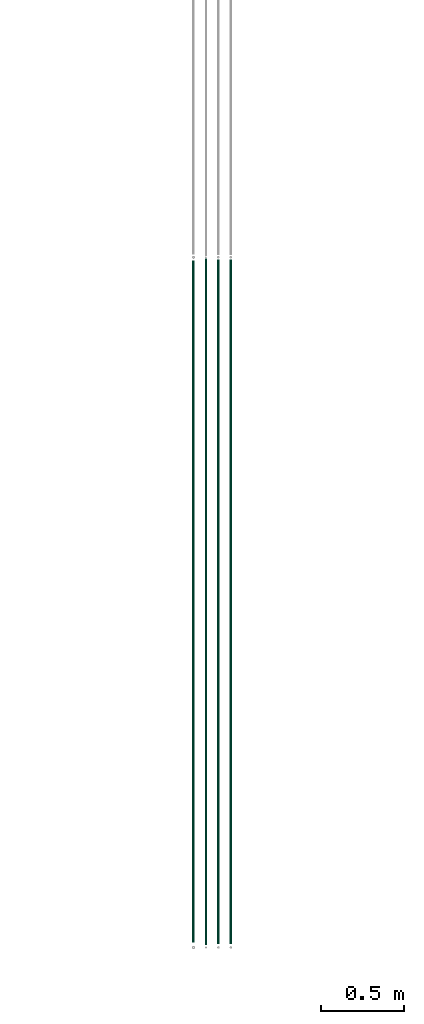
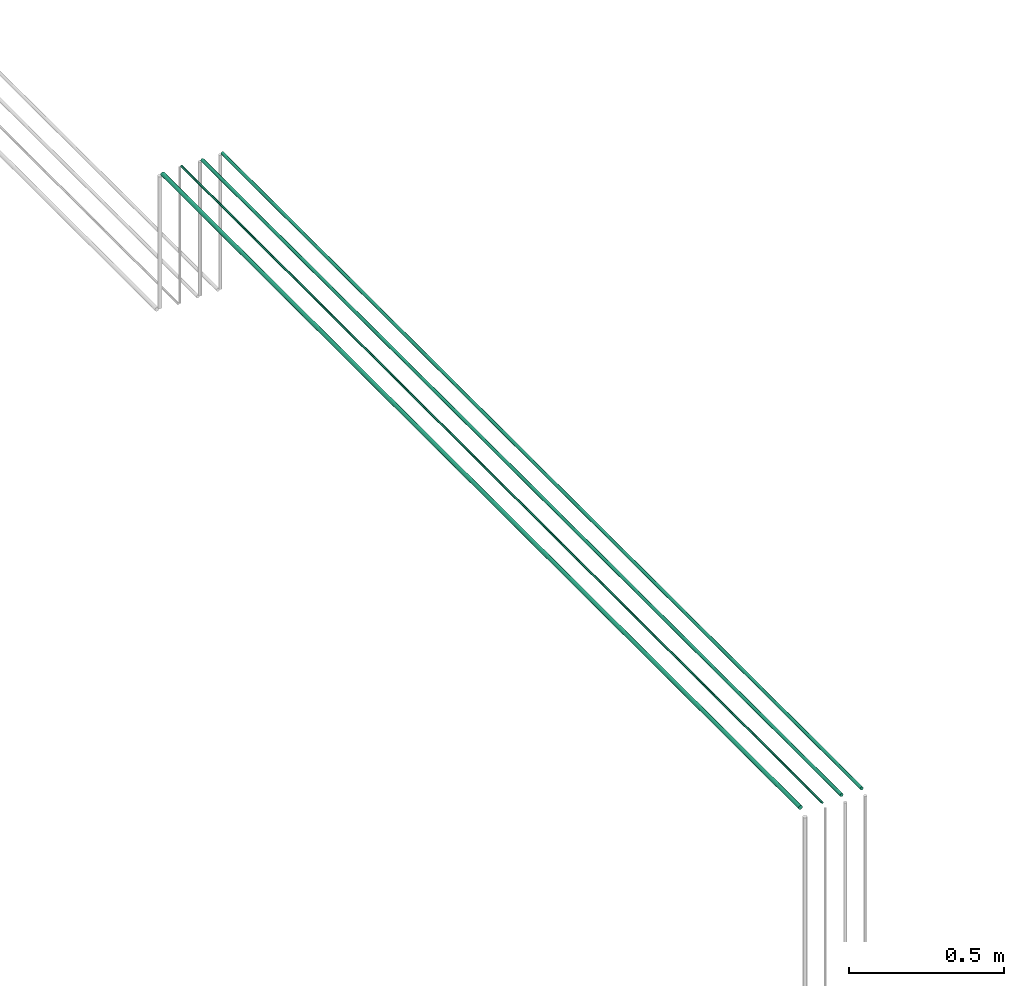
# One storey, part 9 of 65: 4 flow segments.
"""IFC2X3 building model written with IfcOpenShell, lengths in millimetres."""

from ifc_helpers import new_model, entity, si_unit, converted_unit, derived_unit, direction, frame, frame_2d, origin, origin_2d_with_axis, place, context, subcontext, project, spatial, circle, extrude, type_object, element, save


model = new_model("IFC2X3")

# Units and contexts
model_context = context("Model", 3, precision=0.01, world=origin(), true_north=direction((6.12303176911189e-17, 1.0)))
body_context = subcontext(model_context, "Body", "Model", "MODEL_VIEW")
ifc_project = project(units=[si_unit("LENGTHUNIT", "METRE", prefix="MILLI"), si_unit("AREAUNIT", "SQUARE_METRE"), si_unit("VOLUMEUNIT", "CUBIC_METRE"), converted_unit("PLANEANGLEUNIT", "DEGREE", entity("IfcRatioMeasure", 0.0174532925199433), si_unit("PLANEANGLEUNIT", "RADIAN"), dimensions=[0, 0, 0, 0, 0, 0, 0]), si_unit("MASSUNIT", "GRAM", prefix="KILO"), derived_unit("MASSDENSITYUNIT", [(si_unit("MASSUNIT", "GRAM", prefix="KILO"), 1), (si_unit("LENGTHUNIT", "METRE"), -3)]), derived_unit("MOMENTOFINERTIAUNIT", [(si_unit("LENGTHUNIT", "METRE"), 4)]), si_unit("TIMEUNIT", "SECOND"), si_unit("FREQUENCYUNIT", "HERTZ"), si_unit("THERMODYNAMICTEMPERATUREUNIT", "DEGREE_CELSIUS"), derived_unit("THERMALTRANSMITTANCEUNIT", [(si_unit("MASSUNIT", "GRAM", prefix="KILO"), 1), (si_unit("THERMODYNAMICTEMPERATUREUNIT", "KELVIN"), -1), (si_unit("TIMEUNIT", "SECOND"), -3)]), derived_unit("VOLUMETRICFLOWRATEUNIT", [(si_unit("LENGTHUNIT", "METRE"), 3), (si_unit("TIMEUNIT", "SECOND"), -1)]), derived_unit("MASSFLOWRATEUNIT", [(si_unit("MASSUNIT", "GRAM", prefix="KILO"), 1), (si_unit("TIMEUNIT", "SECOND"), -1)]), derived_unit("ROTATIONALFREQUENCYUNIT", [(si_unit("TIMEUNIT", "SECOND"), -1)]), si_unit("ELECTRICCURRENTUNIT", "AMPERE"), si_unit("ELECTRICVOLTAGEUNIT", "VOLT"), si_unit("POWERUNIT", "WATT"), si_unit("FORCEUNIT", "NEWTON", prefix="KILO"), si_unit("ILLUMINANCEUNIT", "LUX"), si_unit("LUMINOUSFLUXUNIT", "LUMEN"), si_unit("LUMINOUSINTENSITYUNIT", "CANDELA"), derived_unit("USERDEFINED", [(si_unit("MASSUNIT", "GRAM", prefix="KILO"), -1), (si_unit("LENGTHUNIT", "METRE"), -2), (si_unit("TIMEUNIT", "SECOND"), 3), (si_unit("LUMINOUSFLUXUNIT", "LUMEN"), 1)]), derived_unit("LINEARVELOCITYUNIT", [(si_unit("LENGTHUNIT", "METRE"), 1), (si_unit("TIMEUNIT", "SECOND"), -1)]), si_unit("PRESSUREUNIT", "PASCAL"), derived_unit("USERDEFINED", [(si_unit("LENGTHUNIT", "METRE"), -2), (si_unit("MASSUNIT", "GRAM", prefix="KILO"), 1), (si_unit("TIMEUNIT", "SECOND"), -2)]), derived_unit("LINEARFORCEUNIT", [(si_unit("MASSUNIT", "GRAM", prefix="KILO"), 1), (si_unit("LENGTHUNIT", "METRE"), 1), (si_unit("TIMEUNIT", "SECOND"), -2), (si_unit("LENGTHUNIT", "METRE"), -1)]), derived_unit("PLANARFORCEUNIT", [(si_unit("MASSUNIT", "GRAM", prefix="KILO"), 1), (si_unit("LENGTHUNIT", "METRE"), 1), (si_unit("TIMEUNIT", "SECOND"), -2), (si_unit("LENGTHUNIT", "METRE"), -2)])], contexts=[model_context])

# Site, building, storey
site_placement = place(None, frame((0.0, -0.00077364408347762, 0.0)))
site = spatial("IfcSite", under=ifc_project, at=site_placement, CompositionType="ELEMENT")
building_placement = place(site_placement, origin())
building = spatial("IfcBuilding", under=site, at=building_placement, CompositionType="ELEMENT")
storey_placement = place(building_placement, frame((0.0, 0.0, 19800.0)))
storey = spatial("IfcBuildingStorey", under=building, at=storey_placement, CompositionType="ELEMENT", Elevation=19800.0)

# Flow segments
pipe_segment_type = type_object("IfcPipeSegmentType", PredefinedType="NOTDEFINED")
flow_segment_1_placement = place(storey_placement, frame((50935.3052438068, 557.0, 3174.40472776419)))
element("IfcFlowSegment", 1, at=flow_segment_1_placement, inside=storey, type_object=pipe_segment_type, context=body_context, shape_type="SweptSolid", body=[
    extrude(circle(Radius=4.0, at=frame_2d((-8.66293703438714e-12, 0.0), x_axis=(1.0, 0.0))), frame((5.59527223591499, 0.0, 5.59527223591499), z_axis=(0.0, 1.0, 0.0), x_axis=(-1.0, 0.0, 0.0)), (0.0, 0.0, 1.0), 4133.00000000001),
])
for number, where in (
    (2, (51008.3052438068, 563.0, 3172.40472776425)),
    (3, (51083.3052438068, 563.0, 3172.40472776415)),
):
    element("IfcFlowSegment", number, at=place(storey_placement, frame(where)), inside=storey, type_object=pipe_segment_type, context=body_context, shape_type="SweptSolid", body=[
        extrude(circle(Radius=6.0, at=frame_2d((-8.66293703438714e-12, 0.0), x_axis=(1.0, 0.0))), frame((7.59527223591454, 0.0, 7.59527223591454), z_axis=(0.0, 1.0, 0.0), x_axis=(-1.0, 0.0, 0.0)), (0.0, 0.0, 1.0), 4123.00000000001),
    ])
flow_segment_2_placement = place(storey_placement, frame((50856.8052438068, 569.0, 3170.90472776367)))
element("IfcFlowSegment", 4, at=flow_segment_2_placement, inside=storey, type_object=pipe_segment_type, context=body_context, shape_type="SweptSolid", body=[
    extrude(circle(Radius=7.5, at=origin_2d_with_axis()), frame((9.09527223591419, 0.0, 9.09527223591419), z_axis=(0.0, 1.0, 0.0), x_axis=(1.0, 0.0, 0.0)), (0.0, 0.0, 1.0), 4113.00000000001),
])

save(model, "model.ifc")
